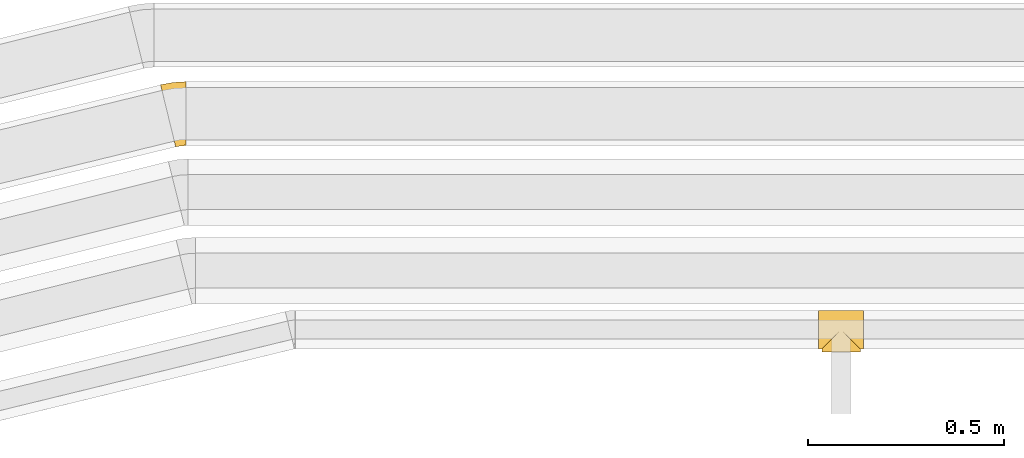
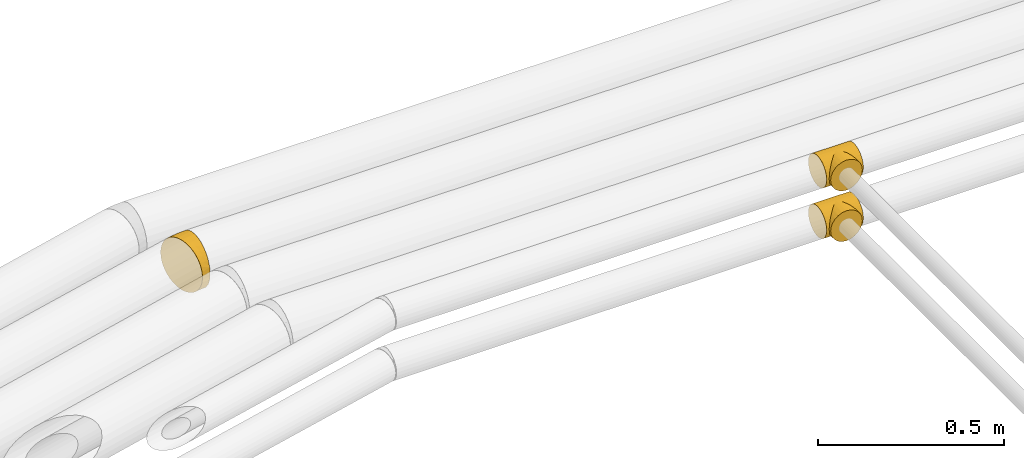
# One storey, part 14 of 93: 3 coverings.
"""IFC2X3 building model written with IfcOpenShell, lengths in millimetres."""

from ifc_helpers import new_model, entity, si_unit, converted_unit, derived_unit, direction, frame, origin, place, context, subcontext, project, spatial, faceted_brep, element, save


model = new_model("IFC2X3")

# Units and contexts
model_context = context("Model", 3, precision=0.01, world=origin(), true_north=direction((6.12303176911189e-17, 1.0)))
body_context = subcontext(model_context, "Body", "Model", "MODEL_VIEW")
ifc_project = project(units=[si_unit("LENGTHUNIT", "METRE", prefix="MILLI"), si_unit("AREAUNIT", "SQUARE_METRE"), si_unit("VOLUMEUNIT", "CUBIC_METRE"), converted_unit("PLANEANGLEUNIT", "DEGREE", entity("IfcRatioMeasure", 0.0174532925199433), si_unit("PLANEANGLEUNIT", "RADIAN"), dimensions=[0, 0, 0, 0, 0, 0, 0]), si_unit("MASSUNIT", "GRAM", prefix="KILO"), derived_unit("MASSDENSITYUNIT", [(si_unit("MASSUNIT", "GRAM", prefix="KILO"), 1), (si_unit("LENGTHUNIT", "METRE"), -3)]), derived_unit("MOMENTOFINERTIAUNIT", [(si_unit("LENGTHUNIT", "METRE"), 4)]), si_unit("TIMEUNIT", "SECOND"), si_unit("FREQUENCYUNIT", "HERTZ"), si_unit("THERMODYNAMICTEMPERATUREUNIT", "DEGREE_CELSIUS"), derived_unit("THERMALTRANSMITTANCEUNIT", [(si_unit("MASSUNIT", "GRAM", prefix="KILO"), 1), (si_unit("THERMODYNAMICTEMPERATUREUNIT", "KELVIN"), -1), (si_unit("TIMEUNIT", "SECOND"), -3)]), derived_unit("VOLUMETRICFLOWRATEUNIT", [(si_unit("LENGTHUNIT", "METRE"), 3), (si_unit("TIMEUNIT", "SECOND"), -1)]), derived_unit("MASSFLOWRATEUNIT", [(si_unit("MASSUNIT", "GRAM", prefix="KILO"), 1), (si_unit("TIMEUNIT", "SECOND"), -1)]), derived_unit("ROTATIONALFREQUENCYUNIT", [(si_unit("TIMEUNIT", "SECOND"), -1)]), si_unit("ELECTRICCURRENTUNIT", "AMPERE"), si_unit("ELECTRICVOLTAGEUNIT", "VOLT"), si_unit("POWERUNIT", "WATT"), si_unit("FORCEUNIT", "NEWTON", prefix="KILO"), si_unit("ILLUMINANCEUNIT", "LUX"), si_unit("LUMINOUSFLUXUNIT", "LUMEN"), si_unit("LUMINOUSINTENSITYUNIT", "CANDELA"), derived_unit("USERDEFINED", [(si_unit("MASSUNIT", "GRAM", prefix="KILO"), -1), (si_unit("LENGTHUNIT", "METRE"), -2), (si_unit("TIMEUNIT", "SECOND"), 3), (si_unit("LUMINOUSFLUXUNIT", "LUMEN"), 1)]), derived_unit("LINEARVELOCITYUNIT", [(si_unit("LENGTHUNIT", "METRE"), 1), (si_unit("TIMEUNIT", "SECOND"), -1)]), si_unit("PRESSUREUNIT", "PASCAL"), derived_unit("USERDEFINED", [(si_unit("LENGTHUNIT", "METRE"), -2), (si_unit("MASSUNIT", "GRAM", prefix="KILO"), 1), (si_unit("TIMEUNIT", "SECOND"), -2)]), derived_unit("LINEARFORCEUNIT", [(si_unit("MASSUNIT", "GRAM", prefix="KILO"), 1), (si_unit("LENGTHUNIT", "METRE"), 1), (si_unit("TIMEUNIT", "SECOND"), -2), (si_unit("LENGTHUNIT", "METRE"), -1)]), derived_unit("PLANARFORCEUNIT", [(si_unit("MASSUNIT", "GRAM", prefix="KILO"), 1), (si_unit("LENGTHUNIT", "METRE"), 1), (si_unit("TIMEUNIT", "SECOND"), -2), (si_unit("LENGTHUNIT", "METRE"), -2)])], contexts=[model_context])

# Site, building, storey
site_placement = place(None, origin())
site = spatial("IfcSite", under=ifc_project, at=site_placement, CompositionType="ELEMENT")
building_placement = place(site_placement, origin())
building = spatial("IfcBuilding", under=site, at=building_placement, CompositionType="ELEMENT")
storey_placement = place(building_placement, frame((0.0, 0.0, -4200.0)))
storey = spatial("IfcBuildingStorey", under=building, at=storey_placement, CompositionType="ELEMENT", Elevation=-4200.0)

# Coverings
covering_1_placement = place(storey_placement, frame((-3759.84, 13693.0, 2508.06)))
element("IfcCovering", 1, at=covering_1_placement, inside=storey, Name=":ADSK_", ObjectType=":ADSK_", PredefinedType="INSULATION", context=body_context, shape_type="Brep", body=[
    faceted_brep([(63.62, 50.38, 2.04), (114.0, 57.0, 1.6), (114.0, 44.28, 3.27), (114.0, 32.42, 8.18), (76.6, 37.4, 5.67), (88.72, 25.28, 13.2), (114.0, 22.25, 15.99), (82.82, 31.18, 8.92), (57.0, 57.0, 1.6), (50.38, 50.38, 2.04), (0.0, 57.0, 1.6), (105.71, 8.29, 46.1), (114.0, 8.69, 44.38), (114.0, 8.27, 47.57), (70.17, 43.83, 3.39), (106.15, 7.85, 50.75), (114.0, 7.85, 50.75), (0.0, 8.27, 47.57), (7.85, 7.85, 50.75), (0.0, 7.85, 50.75), (94.16, 19.84, 18.57), (114.0, 14.43, 26.17), (114.0, 11.98, 32.1), (114.0, 9.52, 38.02), (104.0, 10.0, 37.11), (105.26, 8.74, 41.45), (98.93, 15.07, 25.1), (102.75, 11.25, 32.77), (114.0, 9.11, 41.2), (114.0, 8.27, 53.93), (114.0, 8.69, 57.11), (105.6, 8.4, 55.89), (105.06, 8.94, 61.04), (114.0, 9.11, 60.29), (114.0, 9.52, 63.47), (102.0, 12.0, 70.52), (114.0, 11.98, 69.39), (114.0, 14.43, 75.32), (103.53, 10.47, 65.78), (97.43, 16.57, 78.69), (114.0, 18.34, 80.41), (91.82, 22.18, 85.44), (99.71, 14.29, 74.6), (105.88, 8.12, 53.32), (114.0, 22.25, 85.5), (85.5, 28.5, 90.79), (114.0, 32.42, 93.31), (78.71, 35.29, 94.84), (114.0, 44.28, 98.22), (64.35, 49.65, 99.34), (114.0, 57.0, 99.9), (8.12, 8.12, 53.32), (71.62, 42.38, 97.67), (57.0, 57.0, 99.9), (49.65, 49.65, 99.34), (0.0, 57.0, 99.9), (0.0, 99.57, 75.32), (0.0, 104.48, 63.47), (0.0, 106.15, 50.75), (0.0, 104.48, 38.02), (0.0, 99.57, 26.17), (0.0, 91.75, 15.99), (0.0, 81.57, 8.18), (0.0, 69.72, 3.27), (0.0, 44.28, 3.27), (0.0, 32.42, 8.18), (0.0, 22.25, 15.99), (0.0, 14.43, 26.17), (0.0, 11.98, 32.1), (0.0, 9.52, 38.02), (0.0, 9.11, 41.2), (0.0, 8.69, 44.38), (0.0, 8.27, 53.93), (0.0, 8.69, 57.11), (0.0, 9.11, 60.29), (0.0, 9.52, 63.47), (0.0, 11.98, 69.39), (0.0, 14.43, 75.32), (0.0, 18.34, 80.41), (0.0, 22.25, 85.5), (0.0, 32.42, 93.31), (0.0, 44.28, 98.22), (0.0, 69.72, 98.22), (0.0, 81.57, 93.31), (0.0, 91.75, 85.5), (114.0, 69.72, 3.27), (114.0, 81.57, 8.18), (114.0, 91.75, 15.99), (114.0, 99.57, 26.17), (114.0, 104.48, 38.02), (114.0, 106.15, 50.75), (114.0, 104.48, 63.47), (114.0, 99.57, 75.32), (114.0, 91.75, 85.5), (114.0, 81.57, 93.31), (114.0, 69.72, 98.22), (43.83, 43.83, 3.39), (37.4, 37.4, 5.67), (8.29, 8.29, 46.1), (31.18, 31.18, 8.92), (25.28, 25.28, 13.2), (8.74, 8.74, 41.45), (19.84, 19.84, 18.57), (15.07, 15.07, 25.1), (10.0, 10.0, 37.11), (11.25, 11.25, 32.77), (12.0, 12.0, 70.52), (10.47, 10.47, 65.78), (16.57, 16.57, 78.69), (8.94, 8.94, 61.04), (22.18, 22.18, 85.44), (14.29, 14.29, 74.6), (8.4, 8.4, 55.89), (35.29, 35.29, 94.84), (42.38, 42.38, 97.67), (28.5, 28.5, 90.79), (69.72, 0.0, 3.27), (81.57, 0.0, 8.18), (91.75, 0.0, 15.99), (99.57, 0.0, 26.17), (102.02, 0.0, 32.1), (104.48, 0.0, 38.02), (104.89, 0.0, 41.2), (105.31, 0.0, 44.38), (105.73, 0.0, 47.57), (106.15, 0.0, 50.75), (105.73, 0.0, 53.93), (105.31, 0.0, 57.11), (104.89, 0.0, 60.29), (104.48, 0.0, 63.47), (102.02, 0.0, 69.39), (99.57, 0.0, 75.32), (95.66, 0.0, 80.41), (91.75, 0.0, 85.5), (81.57, 0.0, 93.31), (69.72, 0.0, 98.22), (57.0, 0.0, 99.9), (44.28, 0.0, 98.22), (32.42, 0.0, 93.31), (22.25, 0.0, 85.5), (18.34, 0.0, 80.41), (14.43, 0.0, 75.32), (11.98, 0.0, 69.39), (9.52, 0.0, 63.47), (9.11, 0.0, 60.29), (8.69, 0.0, 57.11), (8.27, 0.0, 53.93), (7.85, 0.0, 50.75), (8.27, 0.0, 47.57), (8.69, 0.0, 44.38), (9.11, 0.0, 41.2), (9.52, 0.0, 38.02), (11.98, 0.0, 32.1), (14.43, 0.0, 26.17), (22.25, 0.0, 15.99), (32.42, 0.0, 8.18), (44.28, 0.0, 3.27), (57.0, 0.0, 1.6)], [[[0, 1, 2]], [[2, 3, 4]], [[5, 3, 6]], [[5, 7, 3]], [[0, 8, 1]], [[8, 9, 10]], [[11, 12, 13]], [[4, 14, 2]], [[7, 4, 3]], [[0, 2, 14]], [[15, 13, 16]], [[17, 18, 19]], [[20, 6, 21]], [[22, 23, 24]], [[15, 11, 13]], [[23, 25, 24]], [[26, 20, 21]], [[27, 21, 22]], [[27, 22, 24]], [[25, 12, 11]], [[25, 23, 28, 12]], [[26, 21, 27]], [[6, 20, 5]], [[29, 30, 31]], [[32, 30, 33, 34]], [[35, 36, 37]], [[38, 36, 35]], [[38, 32, 34]], [[39, 37, 40]], [[41, 39, 40]], [[35, 37, 39, 42]], [[43, 16, 29]], [[40, 44, 41]], [[45, 44, 46]], [[47, 46, 48]], [[49, 48, 50]], [[47, 45, 46]], [[16, 43, 15]], [[51, 19, 18]], [[49, 52, 48]], [[53, 49, 50]], [[54, 53, 55]], [[30, 32, 31]], [[47, 48, 52]], [[36, 38, 34]], [[44, 45, 41]], [[29, 31, 43]], [[56, 57, 58, 59, 60, 61, 62, 63, 10, 64, 65, 66, 67, 68, 69, 70, 71, 17, 19, 72, 73, 74, 75, 76, 77, 78, 79, 80, 81, 55, 82, 83, 84]], [[85, 86, 87, 88, 89, 90, 91, 92, 93, 94, 95, 50, 48, 46, 44, 40, 37, 36, 34, 33, 30, 29, 16, 13, 12, 28, 23, 22, 21, 6, 3, 2, 1]], [[88, 87, 61, 60]], [[58, 90, 89, 59]], [[89, 88, 60, 59]], [[62, 86, 85, 63]], [[1, 8, 10, 63, 85]], [[61, 87, 86, 62]], [[96, 97, 64]], [[18, 17, 98]], [[9, 96, 64]], [[10, 9, 64]], [[65, 99, 100]], [[65, 64, 97]], [[71, 101, 98]], [[65, 100, 66]], [[99, 65, 97]], [[102, 103, 67]], [[104, 68, 105]], [[104, 101, 69]], [[68, 104, 69]], [[103, 105, 67]], [[66, 102, 67]], [[101, 71, 70, 69]], [[68, 67, 105]], [[98, 17, 71]], [[102, 66, 100]], [[106, 76, 107]], [[106, 77, 76]], [[77, 108, 78]], [[109, 75, 74, 73]], [[110, 78, 108]], [[111, 108, 77, 106]], [[19, 51, 72]], [[109, 73, 112]], [[72, 51, 112]], [[76, 75, 107]], [[110, 79, 78]], [[75, 109, 107]], [[113, 114, 81]], [[114, 54, 81]], [[79, 115, 80]], [[115, 79, 110]], [[113, 80, 115]], [[113, 81, 80]], [[54, 55, 81]], [[112, 73, 72]], [[53, 50, 95, 82, 55]], [[82, 95, 94, 83]], [[94, 93, 84, 83]], [[84, 93, 92, 56]], [[56, 92, 91, 57]], [[57, 91, 90, 58]], [[116, 117, 118, 119, 120, 121, 122, 123, 124, 125, 126, 127, 128, 129, 130, 131, 132, 133, 134, 135, 136, 137, 138, 139, 140, 141, 142, 143, 144, 145, 146, 147, 148, 149, 150, 151, 152, 153, 154, 155, 156, 157]], [[25, 123, 122, 121]], [[119, 118, 20]], [[15, 124, 11]], [[27, 120, 119]], [[124, 15, 125]], [[124, 123, 11]], [[120, 24, 121]], [[26, 27, 119]], [[20, 26, 119]], [[24, 120, 27]], [[25, 121, 24]], [[118, 5, 20]], [[7, 5, 117]], [[117, 5, 118]], [[4, 117, 116]], [[0, 116, 157]], [[4, 7, 117]], [[0, 14, 116]], [[8, 0, 157]], [[4, 116, 14]], [[123, 25, 11]], [[9, 157, 156]], [[156, 155, 97]], [[100, 155, 154]], [[100, 99, 155]], [[9, 8, 157]], [[98, 149, 148]], [[97, 96, 156]], [[99, 97, 155]], [[9, 156, 96]], [[18, 148, 147]], [[102, 154, 153]], [[152, 151, 104]], [[18, 98, 148]], [[151, 101, 104]], [[103, 102, 153]], [[105, 153, 152]], [[105, 152, 104]], [[101, 149, 98]], [[101, 151, 150, 149]], [[103, 153, 105]], [[154, 102, 100]], [[146, 145, 112]], [[109, 145, 144, 143]], [[106, 142, 141]], [[107, 142, 106]], [[107, 109, 143]], [[108, 141, 140]], [[110, 108, 140]], [[106, 141, 108, 111]], [[51, 147, 146]], [[140, 139, 110]], [[115, 139, 138]], [[113, 138, 137]], [[54, 137, 136]], [[113, 115, 138]], [[147, 51, 18]], [[54, 114, 137]], [[53, 54, 136]], [[145, 109, 112]], [[113, 137, 114]], [[142, 107, 143]], [[139, 115, 110]], [[146, 112, 51]], [[49, 136, 135]], [[135, 134, 47]], [[45, 134, 133]], [[45, 47, 134]], [[43, 125, 15]], [[49, 53, 136]], [[32, 129, 128, 127]], [[47, 52, 135]], [[49, 135, 52]], [[31, 127, 126]], [[131, 35, 42, 39]], [[125, 43, 126]], [[39, 132, 131]], [[130, 129, 38]], [[43, 31, 126]], [[41, 133, 132]], [[41, 132, 39]], [[35, 130, 38]], [[32, 127, 31]], [[35, 131, 130]], [[129, 32, 38]], [[133, 41, 45]]]),
])
covering_2_placement = place(storey_placement, frame((-3759.84, 13693.0, 2342.1)))
element("IfcCovering", 2, at=covering_2_placement, inside=storey, Name=":ADSK_", ObjectType=":ADSK_", PredefinedType="INSULATION", context=body_context, shape_type="Brep", body=[
    faceted_brep([(0.0, 8.27, 47.57), (0.0, 8.69, 44.38), (8.4, 8.4, 45.6), (8.94, 8.94, 40.45), (0.0, 9.11, 41.2), (0.0, 9.52, 38.02), (12.0, 12.0, 30.97), (0.0, 11.98, 32.1), (0.0, 14.43, 26.17), (10.47, 10.47, 35.71), (16.57, 16.57, 22.8), (0.0, 18.34, 21.08), (22.18, 22.18, 16.05), (14.29, 14.29, 26.89), (8.12, 8.12, 48.17), (0.0, 7.85, 50.75), (0.0, 22.25, 15.99), (28.5, 28.5, 10.7), (0.0, 32.42, 8.18), (35.29, 35.29, 6.65), (0.0, 44.28, 3.27), (49.65, 49.65, 2.15), (0.0, 57.0, 1.6), (7.85, 7.85, 50.75), (105.88, 8.12, 48.17), (114.0, 7.85, 50.75), (106.15, 7.85, 50.75), (42.38, 42.38, 3.82), (57.0, 57.0, 1.6), (64.35, 49.65, 2.15), (114.0, 57.0, 1.6), (50.38, 50.38, 99.45), (0.0, 57.0, 99.9), (0.0, 44.28, 98.22), (0.0, 32.42, 93.31), (37.4, 37.4, 95.82), (25.28, 25.28, 88.29), (0.0, 22.25, 85.5), (31.18, 31.18, 92.57), (57.0, 57.0, 99.9), (63.62, 50.38, 99.45), (114.0, 57.0, 99.9), (8.29, 8.29, 55.39), (0.0, 8.69, 57.11), (0.0, 8.27, 53.93), (43.83, 43.83, 98.1), (114.0, 8.27, 53.93), (19.84, 19.84, 82.92), (0.0, 14.43, 75.32), (0.0, 11.98, 69.39), (0.0, 9.52, 63.47), (10.0, 10.0, 64.38), (8.74, 8.74, 60.04), (15.07, 15.07, 76.39), (11.25, 11.25, 68.72), (0.0, 9.11, 60.29), (114.0, 99.57, 26.17), (114.0, 104.48, 38.02), (114.0, 106.15, 50.75), (114.0, 104.48, 63.47), (114.0, 99.57, 75.32), (114.0, 91.75, 85.5), (114.0, 81.57, 93.31), (114.0, 69.72, 98.22), (114.0, 44.28, 98.22), (114.0, 32.42, 93.31), (114.0, 22.25, 85.5), (114.0, 14.43, 75.32), (114.0, 11.98, 69.39), (114.0, 9.52, 63.47), (114.0, 9.11, 60.29), (114.0, 8.69, 57.11), (114.0, 8.27, 47.57), (114.0, 8.69, 44.38), (114.0, 9.11, 41.2), (114.0, 9.52, 38.02), (114.0, 11.98, 32.1), (114.0, 14.43, 26.17), (114.0, 18.34, 21.08), (114.0, 22.25, 15.99), (114.0, 32.42, 8.18), (114.0, 44.28, 3.27), (114.0, 69.72, 3.27), (114.0, 81.57, 8.18), (114.0, 91.75, 15.99), (0.0, 69.72, 98.22), (0.0, 81.57, 93.31), (0.0, 91.75, 85.5), (0.0, 99.57, 75.32), (0.0, 104.48, 63.47), (0.0, 106.15, 50.75), (0.0, 104.48, 38.02), (0.0, 99.57, 26.17), (0.0, 91.75, 15.99), (0.0, 81.57, 8.18), (0.0, 69.72, 3.27), (70.17, 43.83, 98.1), (76.6, 37.4, 95.82), (105.71, 8.29, 55.39), (82.82, 31.18, 92.57), (88.72, 25.28, 88.29), (105.26, 8.74, 60.04), (94.16, 19.84, 82.92), (98.93, 15.07, 76.39), (104.0, 10.0, 64.38), (102.75, 11.25, 68.72), (102.0, 12.0, 30.97), (103.53, 10.47, 35.71), (97.43, 16.57, 22.8), (105.06, 8.94, 40.45), (91.82, 22.18, 16.05), (99.71, 14.29, 26.89), (105.6, 8.4, 45.6), (78.71, 35.29, 6.65), (71.62, 42.38, 3.82), (85.5, 28.5, 10.7), (44.28, 0.0, 98.22), (32.42, 0.0, 93.31), (22.25, 0.0, 85.5), (14.43, 0.0, 75.32), (11.98, 0.0, 69.39), (9.52, 0.0, 63.47), (9.11, 0.0, 60.29), (8.69, 0.0, 57.11), (8.27, 0.0, 53.93), (7.85, 0.0, 50.75), (8.27, 0.0, 47.57), (8.69, 0.0, 44.38), (9.11, 0.0, 41.2), (9.52, 0.0, 38.02), (11.98, 0.0, 32.1), (14.43, 0.0, 26.17), (18.34, 0.0, 21.08), (22.25, 0.0, 15.99), (32.42, 0.0, 8.18), (44.28, 0.0, 3.27), (57.0, 0.0, 1.6), (69.72, 0.0, 3.27), (81.57, 0.0, 8.18), (91.75, 0.0, 15.99), (95.66, 0.0, 21.08), (99.57, 0.0, 26.17), (102.02, 0.0, 32.1), (104.48, 0.0, 38.02), (104.89, 0.0, 41.2), (105.31, 0.0, 44.38), (105.73, 0.0, 47.57), (106.15, 0.0, 50.75), (105.73, 0.0, 53.93), (105.31, 0.0, 57.11), (104.89, 0.0, 60.29), (104.48, 0.0, 63.47), (102.02, 0.0, 69.39), (99.57, 0.0, 75.32), (91.75, 0.0, 85.5), (81.57, 0.0, 93.31), (69.72, 0.0, 98.22), (57.0, 0.0, 99.9)], [[[0, 1, 2]], [[3, 1, 4, 5]], [[6, 7, 8]], [[9, 7, 6]], [[9, 3, 5]], [[10, 8, 11]], [[12, 10, 11]], [[6, 8, 10, 13]], [[14, 15, 0]], [[11, 16, 12]], [[17, 16, 18]], [[19, 18, 20]], [[21, 20, 22]], [[19, 17, 18]], [[15, 14, 23]], [[24, 25, 26]], [[21, 27, 20]], [[28, 21, 22]], [[29, 28, 30]], [[1, 3, 2]], [[19, 20, 27]], [[7, 9, 5]], [[16, 17, 12]], [[0, 2, 14]], [[31, 32, 33]], [[33, 34, 35]], [[36, 34, 37]], [[36, 38, 34]], [[31, 39, 32]], [[39, 40, 41]], [[42, 43, 44]], [[35, 45, 33]], [[38, 35, 34]], [[31, 33, 45]], [[23, 44, 15]], [[46, 26, 25]], [[47, 37, 48]], [[49, 50, 51]], [[23, 42, 44]], [[50, 52, 51]], [[53, 47, 48]], [[54, 48, 49]], [[54, 49, 51]], [[52, 43, 42]], [[52, 50, 55, 43]], [[53, 48, 54]], [[37, 47, 36]], [[56, 57, 58, 59, 60, 61, 62, 63, 41, 64, 65, 66, 67, 68, 69, 70, 71, 46, 25, 72, 73, 74, 75, 76, 77, 78, 79, 80, 81, 30, 82, 83, 84]], [[85, 86, 87, 88, 89, 90, 91, 92, 93, 94, 95, 22, 20, 18, 16, 11, 8, 7, 5, 4, 1, 0, 15, 44, 43, 55, 50, 49, 48, 37, 34, 33, 32]], [[88, 87, 61, 60]], [[58, 90, 89, 59]], [[89, 88, 60, 59]], [[62, 86, 85, 63]], [[32, 39, 41, 63, 85]], [[61, 87, 86, 62]], [[96, 97, 64]], [[26, 46, 98]], [[40, 96, 64]], [[41, 40, 64]], [[65, 99, 100]], [[65, 64, 97]], [[71, 101, 98]], [[65, 100, 66]], [[99, 65, 97]], [[102, 103, 67]], [[104, 68, 105]], [[104, 101, 69]], [[68, 104, 69]], [[103, 105, 67]], [[66, 102, 67]], [[101, 71, 70, 69]], [[68, 67, 105]], [[98, 46, 71]], [[102, 66, 100]], [[106, 76, 107]], [[106, 77, 76]], [[77, 108, 78]], [[109, 75, 74, 73]], [[110, 78, 108]], [[111, 108, 77, 106]], [[25, 24, 72]], [[109, 73, 112]], [[72, 24, 112]], [[76, 75, 107]], [[110, 79, 78]], [[75, 109, 107]], [[113, 114, 81]], [[114, 29, 81]], [[79, 115, 80]], [[115, 79, 110]], [[113, 80, 115]], [[113, 81, 80]], [[29, 30, 81]], [[112, 73, 72]], [[28, 22, 95, 82, 30]], [[82, 95, 94, 83]], [[94, 93, 84, 83]], [[84, 93, 92, 56]], [[56, 92, 91, 57]], [[57, 91, 90, 58]], [[116, 117, 118, 119, 120, 121, 122, 123, 124, 125, 126, 127, 128, 129, 130, 131, 132, 133, 134, 135, 136, 137, 138, 139, 140, 141, 142, 143, 144, 145, 146, 147, 148, 149, 150, 151, 152, 153, 154, 155, 156, 157]], [[52, 123, 122, 121]], [[119, 118, 47]], [[23, 124, 42]], [[54, 120, 119]], [[124, 23, 125]], [[124, 123, 42]], [[120, 51, 121]], [[53, 54, 119]], [[47, 53, 119]], [[51, 120, 54]], [[52, 121, 51]], [[118, 36, 47]], [[38, 36, 117]], [[117, 36, 118]], [[35, 117, 116]], [[31, 116, 157]], [[35, 38, 117]], [[31, 45, 116]], [[39, 31, 157]], [[35, 116, 45]], [[123, 52, 42]], [[40, 157, 156]], [[156, 155, 97]], [[100, 155, 154]], [[100, 99, 155]], [[40, 39, 157]], [[98, 149, 148]], [[97, 96, 156]], [[99, 97, 155]], [[40, 156, 96]], [[26, 148, 147]], [[102, 154, 153]], [[152, 151, 104]], [[26, 98, 148]], [[151, 101, 104]], [[103, 102, 153]], [[105, 153, 152]], [[105, 152, 104]], [[101, 149, 98]], [[101, 151, 150, 149]], [[103, 153, 105]], [[154, 102, 100]], [[146, 145, 112]], [[109, 145, 144, 143]], [[106, 142, 141]], [[107, 142, 106]], [[107, 109, 143]], [[108, 141, 140]], [[110, 108, 140]], [[106, 141, 108, 111]], [[24, 147, 146]], [[140, 139, 110]], [[115, 139, 138]], [[113, 138, 137]], [[29, 137, 136]], [[113, 115, 138]], [[147, 24, 26]], [[29, 114, 137]], [[28, 29, 136]], [[145, 109, 112]], [[113, 137, 114]], [[142, 107, 143]], [[139, 115, 110]], [[146, 112, 24]], [[21, 136, 135]], [[135, 134, 19]], [[17, 134, 133]], [[17, 19, 134]], [[14, 125, 23]], [[21, 28, 136]], [[3, 129, 128, 127]], [[19, 27, 135]], [[21, 135, 27]], [[2, 127, 126]], [[131, 6, 13, 10]], [[125, 14, 126]], [[10, 132, 131]], [[130, 129, 9]], [[14, 2, 126]], [[12, 133, 132]], [[12, 132, 10]], [[6, 130, 9]], [[3, 127, 2]], [[6, 131, 130]], [[129, 3, 9]], [[133, 12, 17]]]),
])
covering_3_placement = place(storey_placement, frame((-5437.96, 14213.82, 2416.9)))
element("IfcCovering", 3, at=covering_3_placement, inside=storey, Name=":ADSK_", ObjectType=":ADSK_", PredefinedType="INSULATION", context=body_context, shape_type="Brep", body=[
    faceted_brep([(38.73, 7.62, 114.28), (36.94, 14.94, 128.37), (34.54, 24.79, 140.72), (31.62, 36.79, 150.86), (28.28, 50.48, 158.39), (24.66, 65.33, 163.03), (20.9, 80.78, 164.6), (17.13, 96.22, 163.03), (13.51, 111.08, 158.39), (10.17, 124.77, 150.86), (7.25, 136.77, 140.72), (4.85, 146.61, 128.37), (3.06, 153.93, 114.28), (1.97, 158.44, 98.99), (1.6, 159.96, 83.1), (1.97, 158.44, 67.2), (3.06, 153.93, 51.91), (4.85, 146.61, 37.82), (7.25, 136.77, 25.47), (10.17, 124.77, 15.33), (13.51, 111.08, 7.8), (17.13, 96.22, 3.16), (20.9, 80.78, 1.6), (24.66, 65.33, 3.16), (28.28, 50.48, 7.8), (31.62, 36.79, 15.33), (34.54, 24.79, 25.47), (36.94, 14.94, 37.82), (38.73, 7.62, 51.91), (39.83, 3.12, 67.2), (40.2, 1.6, 83.1), (39.83, 3.12, 99.0), (65.89, 7.46, 62.0), (65.89, 15.6, 42.35), (65.89, 28.55, 25.47), (65.89, 45.43, 12.51), (65.89, 65.09, 4.37), (65.89, 86.18, 1.6), (65.89, 107.28, 4.37), (65.89, 126.93, 12.51), (65.89, 143.81, 25.47), (65.89, 156.76, 42.35), (65.89, 164.9, 62.0), (65.89, 167.68, 83.1), (65.89, 164.9, 104.19), (65.89, 156.76, 123.85), (65.89, 143.81, 140.72), (65.89, 126.93, 153.68), (65.89, 107.28, 161.82), (65.89, 86.18, 164.6), (65.89, 65.09, 161.82), (65.89, 45.43, 153.68), (65.89, 28.55, 140.72), (65.89, 15.6, 123.85), (65.89, 7.46, 104.19), (65.89, 4.68, 83.1), (35.68, 147.74, 134.34), (33.51, 165.74, 83.1), (32.37, 162.16, 106.45), (29.57, 155.71, 121.17), (39.88, 136.94, 145.71), (36.81, 123.39, 154.62), (43.23, 84.83, 164.6), (49.27, 34.56, 146.96), (45.06, 63.33, 161.69), (44.32, 47.76, 155.77), (50.78, 13.67, 122.13), (52.95, 3.91, 83.1), (51.62, 23.02, 135.56), (50.78, 13.67, 44.06), (49.27, 34.56, 19.23), (49.68, 22.82, 30.58), (43.23, 84.83, 1.6), (44.32, 47.76, 10.43), (45.06, 63.33, 4.5), (36.81, 123.39, 11.57), (32.37, 162.16, 59.74), (34.04, 136.31, 20.54), (29.57, 155.71, 45.02), (35.67, 147.74, 31.85)], [[[0, 1, 2, 3, 4, 5, 6, 7, 8, 9, 10, 11, 12, 13, 14, 15, 16, 17, 18, 19, 20, 21, 22, 23, 24, 25, 26, 27, 28, 29, 30, 31]], [[32, 33, 34, 35, 36, 37, 38, 39, 40, 41, 42, 43, 44, 45, 46, 47, 48, 49, 50, 51, 52, 53, 54, 55]], [[46, 45, 56]], [[44, 43, 57]], [[56, 11, 10]], [[58, 45, 44]], [[57, 58, 44]], [[59, 45, 58]], [[60, 47, 46]], [[48, 47, 61]], [[48, 62, 49]], [[7, 62, 48]], [[11, 56, 59]], [[45, 59, 56]], [[46, 56, 60]], [[11, 59, 12]], [[13, 58, 57]], [[48, 61, 8]], [[12, 59, 58]], [[13, 12, 58]], [[9, 61, 60]], [[47, 60, 61]], [[62, 7, 6]], [[9, 8, 61]], [[7, 48, 8]], [[10, 9, 60]], [[13, 57, 14]], [[10, 60, 56]], [[50, 49, 62]], [[63, 3, 2]], [[64, 51, 50]], [[3, 65, 4]], [[54, 66, 0]], [[54, 53, 66]], [[54, 67, 55]], [[31, 67, 54]], [[52, 51, 63]], [[52, 63, 68]], [[2, 68, 63]], [[5, 64, 62]], [[53, 68, 66]], [[64, 4, 65]], [[51, 65, 63]], [[6, 5, 62]], [[4, 64, 5]], [[3, 63, 65]], [[31, 30, 67]], [[65, 51, 64]], [[1, 0, 66]], [[1, 68, 2]], [[62, 64, 50]], [[31, 54, 0]], [[68, 53, 52]], [[68, 1, 66]], [[69, 32, 28]], [[35, 34, 70]], [[55, 67, 32]], [[32, 69, 33]], [[69, 71, 33]], [[37, 36, 72]], [[73, 35, 70]], [[25, 73, 70]], [[71, 34, 33]], [[74, 72, 36]], [[27, 71, 69]], [[67, 29, 32]], [[30, 29, 67]], [[72, 74, 23]], [[28, 27, 69]], [[35, 74, 36]], [[25, 24, 73]], [[29, 28, 32]], [[25, 70, 26]], [[26, 71, 27]], [[34, 71, 70]], [[35, 73, 74]], [[23, 22, 72]], [[24, 23, 74]], [[74, 73, 24]], [[70, 71, 26]], [[75, 38, 20]], [[37, 72, 38]], [[41, 76, 42]], [[75, 77, 39]], [[43, 42, 57]], [[78, 41, 79]], [[77, 40, 39]], [[76, 57, 42]], [[57, 76, 15]], [[72, 21, 38]], [[21, 20, 38]], [[19, 75, 20]], [[40, 77, 79]], [[19, 77, 75]], [[18, 79, 77]], [[78, 16, 76]], [[41, 78, 76]], [[15, 14, 57]], [[18, 77, 19]], [[41, 40, 79]], [[76, 16, 15]], [[38, 75, 39]], [[18, 17, 79]], [[17, 78, 79]], [[21, 72, 22]], [[17, 16, 78]]]),
])

save(model, "model.ifc")
